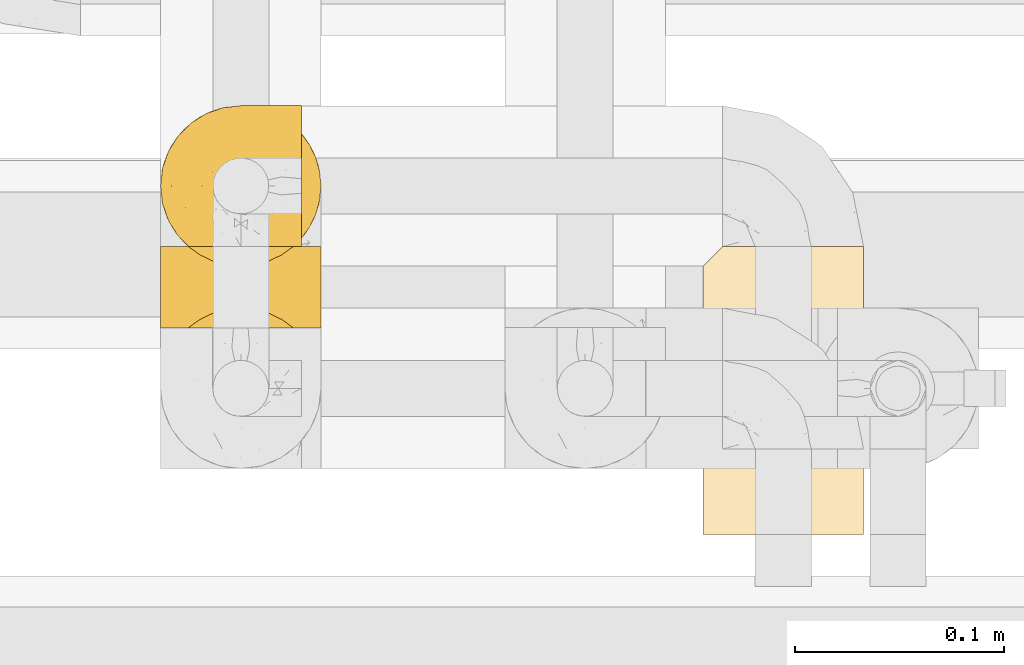
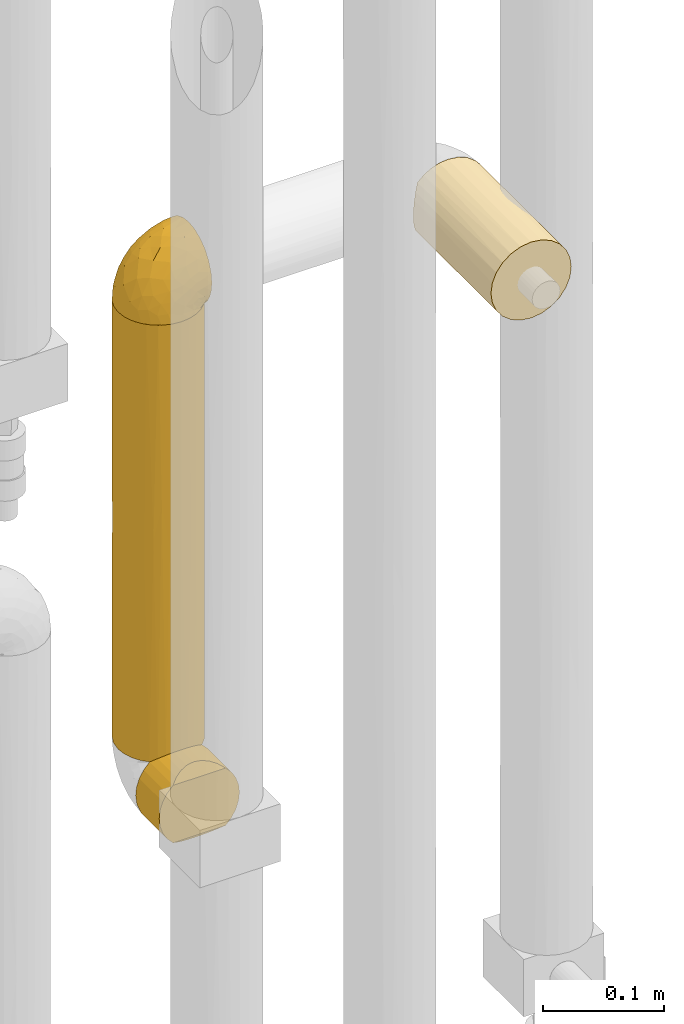
# One storey, part 283 of 827: 4 coverings.
"""IFC2X3 building model written with IfcOpenShell, lengths in millimetres."""

from ifc_helpers import new_model, entity, si_unit, converted_unit, derived_unit, direction, frame, origin, place, context, subcontext, project, spatial, faceted_brep, element, save


model = new_model("IFC2X3")

# Units and contexts
model_context = context("Model", 3, precision=0.01, world=origin(), true_north=direction((6.12303176911189e-17, 1.0)))
body_context = subcontext(model_context, "Body", "Model", "MODEL_VIEW")
ifc_project = project(units=[si_unit("LENGTHUNIT", "METRE", prefix="MILLI"), si_unit("AREAUNIT", "SQUARE_METRE"), si_unit("VOLUMEUNIT", "CUBIC_METRE"), converted_unit("PLANEANGLEUNIT", "DEGREE", entity("IfcRatioMeasure", 0.0174532925199433), si_unit("PLANEANGLEUNIT", "RADIAN"), dimensions=[0, 0, 0, 0, 0, 0, 0]), si_unit("MASSUNIT", "GRAM", prefix="KILO"), derived_unit("MASSDENSITYUNIT", [(si_unit("MASSUNIT", "GRAM", prefix="KILO"), 1), (si_unit("LENGTHUNIT", "METRE"), -3)]), derived_unit("MOMENTOFINERTIAUNIT", [(si_unit("LENGTHUNIT", "METRE"), 4)]), si_unit("TIMEUNIT", "SECOND"), si_unit("FREQUENCYUNIT", "HERTZ"), si_unit("THERMODYNAMICTEMPERATUREUNIT", "DEGREE_CELSIUS"), derived_unit("THERMALTRANSMITTANCEUNIT", [(si_unit("MASSUNIT", "GRAM", prefix="KILO"), 1), (si_unit("THERMODYNAMICTEMPERATUREUNIT", "KELVIN"), -1), (si_unit("TIMEUNIT", "SECOND"), -3)]), derived_unit("VOLUMETRICFLOWRATEUNIT", [(si_unit("LENGTHUNIT", "METRE"), 3), (si_unit("TIMEUNIT", "SECOND"), -1)]), derived_unit("MASSFLOWRATEUNIT", [(si_unit("MASSUNIT", "GRAM", prefix="KILO"), 1), (si_unit("TIMEUNIT", "SECOND"), -1)]), derived_unit("ROTATIONALFREQUENCYUNIT", [(si_unit("TIMEUNIT", "SECOND"), -1)]), si_unit("ELECTRICCURRENTUNIT", "AMPERE"), si_unit("ELECTRICVOLTAGEUNIT", "VOLT"), si_unit("POWERUNIT", "WATT"), si_unit("FORCEUNIT", "NEWTON", prefix="KILO"), si_unit("ILLUMINANCEUNIT", "LUX"), si_unit("LUMINOUSFLUXUNIT", "LUMEN"), si_unit("LUMINOUSINTENSITYUNIT", "CANDELA"), derived_unit("USERDEFINED", [(si_unit("MASSUNIT", "GRAM", prefix="KILO"), -1), (si_unit("LENGTHUNIT", "METRE"), -2), (si_unit("TIMEUNIT", "SECOND"), 3), (si_unit("LUMINOUSFLUXUNIT", "LUMEN"), 1)]), derived_unit("LINEARVELOCITYUNIT", [(si_unit("LENGTHUNIT", "METRE"), 1), (si_unit("TIMEUNIT", "SECOND"), -1)]), si_unit("PRESSUREUNIT", "PASCAL"), derived_unit("USERDEFINED", [(si_unit("LENGTHUNIT", "METRE"), -2), (si_unit("MASSUNIT", "GRAM", prefix="KILO"), 1), (si_unit("TIMEUNIT", "SECOND"), -2)]), derived_unit("LINEARFORCEUNIT", [(si_unit("MASSUNIT", "GRAM", prefix="KILO"), 1), (si_unit("LENGTHUNIT", "METRE"), 1), (si_unit("TIMEUNIT", "SECOND"), -2), (si_unit("LENGTHUNIT", "METRE"), -1)]), derived_unit("PLANARFORCEUNIT", [(si_unit("MASSUNIT", "GRAM", prefix="KILO"), 1), (si_unit("LENGTHUNIT", "METRE"), 1), (si_unit("TIMEUNIT", "SECOND"), -2), (si_unit("LENGTHUNIT", "METRE"), -2)])], contexts=[model_context])

# Site, building, storey
site_placement = place(None, origin())
site = spatial("IfcSite", under=ifc_project, at=site_placement, CompositionType="ELEMENT")
building_placement = place(site_placement, origin())
building = spatial("IfcBuilding", under=site, at=building_placement, CompositionType="ELEMENT")
storey_placement = place(building_placement, frame((0.0, 0.0, 28200.0)))
storey = spatial("IfcBuildingStorey", under=building, at=storey_placement, Name="08", CompositionType="ELEMENT", Elevation=28200.0)

# Coverings
covering_1_placement = place(storey_placement, frame((35047.85, 14854.91, 2170.0)))
element("IfcCovering", 1, at=covering_1_placement, inside=storey, Name=":ADSK_", ObjectType=":ADSK_", PredefinedType="INSULATION", context=body_context, shape_type="Brep", body=[
    faceted_brep([(30.06, 0.0, 2.9), (40.0, 0.0, 1.6), (49.93, 0.0, 2.9), (59.2, 0.0, 6.74), (67.15, 0.0, 12.84), (73.25, 0.0, 20.8), (77.09, 0.0, 30.06), (78.4, 0.0, 40.0), (77.09, 0.0, 49.93), (73.25, 0.0, 59.2), (67.15, 0.0, 67.15), (59.2, 0.0, 73.25), (49.93, 0.0, 77.09), (40.0, 0.0, 78.4), (30.06, 0.0, 77.09), (20.8, 0.0, 73.25), (12.84, 0.0, 67.15), (6.74, 0.0, 59.2), (2.9, 0.0, 49.93), (1.6, 0.0, 40.0), (2.9, 0.0, 30.06), (6.74, 0.0, 20.8), (12.84, 0.0, 12.84), (20.8, 0.0, 6.74), (40.0, 137.9, 1.6), (31.79, 137.9, 2.48), (23.98, 137.9, 5.09), (16.91, 137.9, 9.31), (10.9, 137.9, 14.94), (10.9, 137.9, 65.05), (16.91, 137.9, 70.68), (23.98, 137.9, 74.9), (31.79, 137.9, 77.51), (40.0, 137.9, 78.4), (49.93, 137.9, 77.09), (59.2, 137.9, 73.25), (67.15, 137.9, 67.15), (73.25, 137.9, 59.2), (77.09, 137.9, 49.93), (78.4, 137.9, 40.0), (77.09, 137.9, 30.06), (73.25, 137.9, 20.8), (67.15, 137.9, 12.84), (59.2, 137.9, 6.74), (49.93, 137.9, 2.9), (2.2, 129.2, 33.21), (4.0, 131.0, 26.63), (6.92, 133.92, 20.48), (1.6, 128.6, 40.0), (6.92, 133.92, 59.51), (4.0, 131.0, 53.36), (2.2, 129.2, 46.78)], [[[0, 1, 2, 3, 4, 5, 6, 7, 8, 9, 10, 11, 12, 13, 14, 15, 16, 17, 18, 19, 20, 21, 22, 23]], [[24, 25, 26, 27, 28, 29, 30, 31, 32, 33, 34, 35, 36, 37, 38, 39, 40, 41, 42, 43, 44]], [[45, 46, 20]], [[47, 28, 21]], [[46, 47, 21]], [[48, 45, 19]], [[19, 45, 20]], [[46, 21, 20]], [[28, 22, 21]], [[23, 27, 26]], [[0, 26, 25]], [[1, 25, 24]], [[22, 27, 23]], [[23, 26, 0]], [[25, 1, 0]], [[27, 22, 28]], [[2, 1, 24, 44]], [[3, 2, 44, 43]], [[43, 42, 4, 3]], [[6, 5, 41, 40]], [[7, 6, 40, 39]], [[42, 41, 5, 4]], [[8, 7, 39, 38]], [[9, 8, 38, 37]], [[37, 36, 10, 9]], [[12, 11, 35, 34]], [[13, 12, 34, 33]], [[36, 35, 11, 10]], [[13, 33, 32]], [[14, 32, 31]], [[15, 31, 30]], [[13, 32, 14]], [[14, 31, 15]], [[30, 16, 15]], [[30, 29, 16]], [[29, 49, 17]], [[50, 51, 18]], [[49, 50, 17]], [[17, 50, 18]], [[19, 18, 51]], [[48, 19, 51]], [[29, 17, 16]], [[48, 51, 50, 49, 29, 28, 47, 46, 45]]]),
])
covering_2_placement = place(storey_placement, frame((34787.85, 14981.91, 1737.5)))
element("IfcCovering", 2, at=covering_2_placement, inside=storey, Name=":ADSK_", ObjectType=":ADSK_", PredefinedType="INSULATION", context=body_context, shape_type="Brep", body=[
    faceted_brep([(56.01, 5.09, 443.4), (63.08, 9.31, 443.4), (69.1, 14.94, 443.4), (69.1, 65.05, 443.4), (63.08, 70.68, 443.4), (56.01, 74.9, 443.4), (48.2, 77.51, 443.4), (40.0, 78.4, 443.4), (30.06, 77.09, 443.4), (20.8, 73.25, 443.4), (12.84, 67.15, 443.4), (6.74, 59.2, 443.4), (2.9, 49.93, 443.4), (1.6, 40.0, 443.4), (2.9, 30.06, 443.4), (6.74, 20.8, 443.4), (12.84, 12.84, 443.4), (20.8, 6.74, 443.4), (30.06, 2.9, 443.4), (40.0, 1.6, 443.4), (48.2, 2.48, 443.4), (73.25, 59.2, 1.6), (77.09, 49.93, 1.6), (78.4, 40.0, 1.6), (77.51, 31.79, 1.6), (74.9, 23.98, 1.6), (70.68, 16.91, 1.6), (65.05, 10.9, 1.6), (14.94, 10.9, 1.6), (9.31, 16.91, 1.6), (5.09, 23.98, 1.6), (2.48, 31.79, 1.6), (1.6, 40.0, 1.6), (2.9, 49.93, 1.6), (6.74, 59.2, 1.6), (12.84, 67.15, 1.6), (20.8, 73.25, 1.6), (30.06, 77.09, 1.6), (40.0, 78.4, 1.6), (49.93, 77.09, 1.6), (59.2, 73.25, 1.6), (67.15, 67.15, 1.6), (77.02, 29.82, 225.77), (77.79, 33.21, 434.7), (76.0, 26.63, 436.5), (62.49, 8.87, 212.99), (59.51, 6.92, 5.57), (50.17, 2.97, 219.22), (53.36, 4.0, 8.5), (56.58, 5.36, 182.06), (40.0, 1.6, 227.27), (46.78, 2.2, 10.29), (40.0, 1.6, 10.9), (78.4, 40.0, 217.72), (71.12, 17.5, 232.0), (74.63, 23.41, 262.93), (78.4, 40.0, 434.1), (73.07, 20.48, 439.42), (77.02, 50.17, 229.68), (74.64, 56.56, 184.42), (71.11, 62.5, 217.9), (65.94, 68.31, 244.29), (77.79, 46.78, 434.7), (76.0, 53.36, 436.5), (73.07, 59.51, 439.42), (59.66, 72.98, 238.22), (52.17, 76.41, 233.35), (40.0, 78.4, 227.02), (32.5, 77.66, 238.05), (25.3, 75.47, 222.5), (2.33, 47.48, 237.84), (4.52, 54.69, 222.5), (16.62, 70.46, 222.5), (9.53, 63.37, 222.5), (1.6, 40.0, 217.97), (3.58, 27.82, 211.64), (7.01, 20.33, 206.77), (20.48, 6.92, 5.57), (23.43, 5.35, 260.57), (17.49, 8.88, 227.09), (29.82, 2.97, 215.31), (33.21, 2.2, 10.29), (11.69, 14.05, 200.7), (26.63, 4.0, 8.5)], [[[0, 1, 2, 3, 4, 5, 6, 7, 8, 9, 10, 11, 12, 13, 14, 15, 16, 17, 18, 19, 20]], [[21, 22, 23, 24, 25, 26, 27, 28, 29, 30, 31, 32, 33, 34, 35, 36, 37, 38, 39, 40, 41]], [[42, 43, 44]], [[0, 45, 1]], [[46, 27, 45]], [[47, 48, 49]], [[19, 50, 20]], [[45, 49, 46]], [[50, 47, 20]], [[50, 51, 47]], [[52, 51, 50]], [[0, 20, 47]], [[53, 42, 24]], [[45, 54, 2]], [[49, 0, 47]], [[42, 44, 55]], [[2, 1, 45]], [[55, 25, 42]], [[25, 24, 42]], [[25, 55, 54]], [[53, 56, 43]], [[25, 54, 26]], [[57, 2, 54]], [[47, 51, 48]], [[27, 26, 54]], [[53, 43, 42]], [[23, 53, 24]], [[55, 57, 54]], [[0, 49, 45]], [[57, 55, 44]], [[27, 54, 45]], [[46, 49, 48]], [[53, 22, 58]], [[22, 53, 23]], [[22, 59, 58]], [[21, 60, 59]], [[40, 61, 41]], [[62, 58, 63]], [[62, 56, 53]], [[59, 63, 58]], [[59, 64, 63]], [[21, 41, 60]], [[60, 3, 64]], [[53, 58, 62]], [[40, 65, 61]], [[41, 61, 60]], [[40, 39, 66]], [[66, 65, 40]], [[3, 61, 4]], [[67, 7, 6]], [[66, 6, 5]], [[4, 65, 5]], [[67, 66, 39]], [[66, 5, 65]], [[67, 6, 66]], [[38, 67, 39]], [[65, 4, 61]], [[3, 60, 61]], [[64, 59, 60]], [[59, 22, 21]], [[68, 37, 69]], [[33, 70, 71]], [[68, 7, 67, 38]], [[69, 37, 36]], [[68, 38, 37]], [[8, 69, 9]], [[69, 8, 68]], [[72, 10, 9]], [[72, 69, 36]], [[73, 72, 35]], [[13, 70, 32, 74]], [[71, 34, 33]], [[70, 12, 71]], [[13, 12, 70]], [[73, 11, 10]], [[71, 73, 34]], [[32, 70, 33]], [[71, 11, 73]], [[72, 73, 10]], [[35, 72, 36]], [[11, 71, 12]], [[34, 73, 35]], [[7, 68, 8]], [[69, 72, 9]], [[74, 31, 75]], [[75, 30, 76]], [[77, 78, 79]], [[18, 78, 80]], [[76, 30, 29]], [[50, 80, 81]], [[31, 74, 32]], [[75, 31, 30]], [[75, 15, 14]], [[15, 76, 82]], [[78, 18, 17]], [[79, 82, 28]], [[78, 83, 80]], [[15, 82, 16]], [[81, 80, 83]], [[17, 16, 79]], [[81, 52, 50]], [[83, 78, 77]], [[74, 75, 14]], [[78, 17, 79]], [[75, 76, 15]], [[50, 19, 18]], [[18, 80, 50]], [[76, 29, 82]], [[28, 82, 29]], [[77, 79, 28]], [[16, 82, 79]], [[13, 74, 14]], [[2, 57, 44, 43, 56, 62, 63, 64, 3]], [[48, 51, 52, 81, 83, 77, 28, 27, 46]]]),
])
covering_3_placement = place(storey_placement, frame((34787.85, 14952.32, 1670.0)))
element("IfcCovering", 3, at=covering_3_placement, inside=storey, Name=":ADSK_", ObjectType=":ADSK_", PredefinedType="INSULATION", context=body_context, shape_type="Brep", body=[
    faceted_brep([(1.6, 1.6, 40.0), (2.47, 1.6, 31.83), (5.06, 1.6, 24.05), (9.24, 1.6, 17.0), (14.82, 1.6, 11.0), (65.17, 1.6, 11.0), (70.75, 1.6, 17.0), (74.93, 1.6, 24.05), (77.52, 1.6, 31.83), (78.4, 1.6, 40.0), (77.52, 1.6, 48.16), (74.93, 1.6, 55.94), (70.75, 1.6, 62.99), (65.17, 1.6, 69.0), (14.82, 1.6, 69.0), (9.24, 1.6, 62.99), (5.06, 1.6, 55.94), (2.47, 1.6, 48.16), (40.0, 40.49, 1.6), (30.06, 40.49, 2.9), (20.8, 40.49, 6.74), (12.84, 40.49, 12.84), (6.74, 40.49, 20.8), (2.9, 40.49, 30.06), (1.6, 40.49, 40.0), (2.48, 40.49, 48.2), (5.09, 40.49, 56.01), (9.31, 40.49, 63.08), (14.94, 40.49, 69.1), (65.05, 40.49, 69.1), (70.68, 40.49, 63.08), (74.9, 40.49, 56.01), (77.51, 40.49, 48.2), (78.4, 40.49, 40.0), (77.09, 40.49, 30.06), (73.25, 40.49, 20.8), (67.15, 40.49, 12.84), (59.2, 40.49, 6.74), (49.93, 40.49, 2.9), (46.82, 10.38, 2.21), (40.0, 11.0, 1.6), (53.43, 8.57, 4.02), (59.61, 5.61, 6.98), (59.51, 36.52, 73.07), (59.61, 5.61, 73.01), (53.36, 33.59, 76.0), (46.78, 31.8, 77.79), (46.82, 10.38, 77.78), (53.43, 8.57, 75.97), (40.0, 11.0, 78.4), (40.0, 31.19, 78.4), (33.21, 31.8, 77.79), (26.63, 33.59, 76.0), (33.17, 10.38, 77.78), (20.48, 36.52, 73.07), (20.38, 5.61, 73.01), (26.56, 8.57, 75.97), (26.56, 8.57, 4.02), (33.17, 10.38, 2.21), (20.38, 5.61, 6.98)], [[[0, 1, 2, 3, 4, 5, 6, 7, 8, 9, 10, 11, 12, 13, 14, 15, 16, 17]], [[18, 19, 20, 21, 22, 23, 24, 25, 26, 27, 28, 29, 30, 31, 32, 33, 34, 35, 36, 37, 38]], [[39, 40, 18]], [[39, 18, 38]], [[41, 38, 37]], [[41, 39, 38]], [[36, 5, 42]], [[41, 37, 42]], [[42, 37, 36]], [[6, 36, 35]], [[35, 34, 7]], [[33, 8, 34]], [[6, 35, 7]], [[7, 34, 8]], [[33, 9, 8]], [[36, 6, 5]], [[10, 33, 32]], [[11, 32, 31]], [[12, 31, 30]], [[9, 33, 10]], [[11, 10, 32]], [[13, 12, 30]], [[12, 11, 31]], [[30, 29, 13]], [[29, 43, 44]], [[45, 46, 47]], [[43, 45, 48]], [[44, 43, 48]], [[46, 49, 47]], [[47, 48, 45]], [[49, 46, 50]], [[29, 44, 13]], [[51, 52, 53]], [[54, 28, 55]], [[52, 54, 56]], [[50, 51, 49]], [[49, 51, 53]], [[53, 52, 56]], [[54, 55, 56]], [[28, 14, 55]], [[15, 27, 26]], [[16, 26, 25]], [[17, 25, 24]], [[14, 27, 15]], [[16, 15, 26]], [[25, 17, 16]], [[24, 0, 17]], [[27, 14, 28]], [[1, 24, 23]], [[22, 21, 3]], [[2, 23, 22]], [[0, 24, 1]], [[2, 1, 23]], [[3, 2, 22]], [[21, 4, 3]], [[57, 20, 19]], [[19, 18, 58]], [[40, 58, 18]], [[4, 21, 59]], [[58, 57, 19]], [[59, 20, 57]], [[59, 21, 20]], [[59, 57, 58, 40, 39, 41, 42, 5, 4]], [[44, 48, 47, 49, 53, 56, 55, 14, 13]], [[54, 52, 51, 50, 46, 45, 43, 29, 28]]]),
])
covering_4_placement = place(storey_placement, frame((34787.8, 14981.86, 2179.3)))
element("IfcCovering", 4, at=covering_4_placement, inside=storey, Name=":ADSK_", ObjectType=":ADSK_", PredefinedType="INSULATION", context=body_context, shape_type="Brep", body=[
    faceted_brep([(23.36, 5.41, 1.6), (16.07, 9.99, 1.6), (9.98, 16.08, 1.6), (5.4, 23.37, 1.6), (2.56, 31.49, 1.6), (1.6, 40.05, 1.6), (2.56, 48.61, 1.6), (5.41, 56.73, 1.6), (9.99, 64.02, 1.6), (16.08, 70.11, 1.6), (23.37, 74.69, 1.6), (31.49, 77.53, 1.6), (40.05, 78.5, 1.6), (48.15, 77.63, 1.6), (55.88, 75.08, 1.6), (62.9, 70.97, 1.6), (68.89, 65.47, 1.6), (68.89, 63.27, 1.6), (68.89, 61.53, 1.6), (68.89, 59.57, 1.6), (68.89, 57.6, 1.6), (68.89, 55.63, 1.6), (68.89, 53.67, 1.6), (68.89, 51.7, 1.6), (68.89, 49.73, 1.6), (68.89, 47.54, 1.6), (68.89, 45.34, 1.6), (68.89, 43.15, 1.6), (68.89, 40.96, 1.6), (68.89, 38.76, 1.6), (68.89, 36.57, 1.6), (68.89, 34.37, 1.6), (68.89, 32.18, 1.6), (68.89, 29.98, 1.6), (68.89, 27.79, 1.6), (68.89, 25.6, 1.6), (68.89, 23.4, 1.6), (68.89, 21.21, 1.6), (68.89, 19.01, 1.6), (68.89, 16.82, 1.6), (68.89, 14.62, 1.6), (62.89, 9.12, 1.6), (55.86, 5.0, 1.6), (48.13, 2.46, 1.6), (40.05, 1.6, 1.6), (31.49, 2.56, 1.6), (69.15, 65.47, 1.85), (69.15, 70.97, 7.85), (69.15, 75.09, 14.87), (69.15, 77.63, 22.6), (69.15, 78.5, 30.7), (69.15, 77.19, 40.65), (69.15, 73.34, 49.92), (69.15, 67.23, 57.88), (69.15, 59.27, 63.99), (69.15, 50.0, 67.84), (69.15, 40.05, 69.15), (69.15, 30.09, 67.84), (69.15, 20.82, 63.99), (69.15, 12.86, 57.88), (69.15, 6.75, 49.92), (69.15, 2.91, 40.65), (69.15, 1.6, 30.7), (69.15, 2.46, 22.6), (69.15, 5.0, 14.87), (69.15, 9.12, 7.85), (69.15, 14.62, 1.85), (69.15, 16.82, 1.85), (69.15, 17.8, 1.85), (69.15, 19.39, 1.85), (69.15, 20.98, 1.85), (69.15, 22.57, 1.85), (69.15, 24.16, 1.85), (69.15, 25.75, 1.85), (69.15, 27.33, 1.85), (69.15, 28.92, 1.85), (69.15, 30.51, 1.85), (69.15, 32.1, 1.85), (69.15, 33.69, 1.85), (69.15, 35.28, 1.85), (69.15, 36.87, 1.85), (69.15, 38.46, 1.85), (69.15, 40.05, 1.85), (69.15, 41.63, 1.85), (69.15, 43.22, 1.85), (69.15, 44.81, 1.85), (69.15, 46.4, 1.85), (69.15, 47.99, 1.85), (69.15, 49.58, 1.85), (69.15, 51.17, 1.85), (69.15, 52.76, 1.85), (69.15, 54.72, 1.85), (69.15, 56.69, 1.85), (69.15, 58.88, 1.85), (69.15, 61.08, 1.85), (69.15, 63.27, 1.85), (68.96, 37.77, 1.77), (68.97, 36.07, 1.78), (68.97, 32.96, 1.77), (68.97, 31.36, 1.77), (68.95, 56.52, 1.76), (68.96, 54.96, 1.77), (68.98, 18.75, 1.79), (68.97, 58.07, 1.78), (68.97, 50.37, 1.78), (68.98, 23.36, 1.78), (68.97, 24.95, 1.78), (68.97, 42.43, 1.78), (68.94, 15.97, 1.74), (68.98, 51.96, 1.78), (68.98, 53.47, 1.78), (68.96, 48.63, 1.77), (68.97, 63.93, 1.78), (68.98, 40.93, 1.78), (68.98, 29.72, 1.78), (68.97, 62.4, 1.77), (68.96, 60.92, 1.77), (68.97, 17.31, 1.77), (68.97, 21.74, 1.78), (68.98, 34.56, 1.78), (68.96, 20.18, 1.77), (68.97, 14.62, 1.77), (68.94, 14.62, 1.72), (68.92, 14.62, 1.66), (68.97, 65.47, 1.77), (69.02, 65.47, 1.8), (69.08, 65.47, 1.82), (68.98, 59.5, 1.79), (68.97, 47.1, 1.78), (68.98, 45.61, 1.79), (68.97, 28.18, 1.78), (69.08, 14.62, 1.82), (69.02, 14.62, 1.8), (68.96, 26.61, 1.76), (68.92, 65.47, 1.66), (68.94, 65.47, 1.72), (68.97, 39.32, 1.78), (68.96, 44.12, 1.77), (67.02, 72.26, 9.41), (63.33, 76.57, 17.65), (64.61, 71.77, 7.41), (49.27, 78.5, 21.47), (51.4, 77.9, 15.21), (43.94, 78.5, 16.15), (61.87, 78.5, 28.75), (61.54, 75.52, 13.67), (57.95, 76.13, 12.79), (56.12, 77.81, 19.18), (65.41, 72.4, 9.04), (53.1, 76.56, 7.41), (63.04, 71.77, 5.74), (61.33, 72.25, 3.72), (41.99, 78.5, 8.87), (54.6, 78.5, 26.8), (56.6, 75.75, 9.53), (41.58, 78.5, 7.34), (61.54, 75.57, 44.74), (28.67, 76.34, 12.03), (58.75, 77.64, 37.26), (46.12, 63.45, 56.57), (55.56, 70.55, 52.31), (42.09, 71.02, 45.87), (17.15, 66.15, 25.73), (12.68, 60.51, 26.34), (20.17, 63.72, 35.21), (52.38, 75.57, 42.07), (23.76, 72.61, 21.49), (34.7, 76.83, 22.52), (20.5, 72.61, 11.02), (14.64, 67.24, 15.64), (49.4, 47.19, 65.49), (52.34, 54.76, 63.99), (58.67, 63.45, 60.27), (5.82, 52.75, 17.92), (30.64, 53.89, 53.93), (26.66, 46.73, 53.36), (37.53, 48.67, 60.18), (41.11, 55.34, 59.54), (21.38, 40.05, 49.36), (13.72, 50.46, 37.63), (6.74, 40.05, 27.45), (14.06, 40.05, 38.4), (41.77, 77.74, 26.02), (51.58, 77.66, 34.22), (16.28, 57.43, 36.59), (4.3, 40.05, 15.2), (8.62, 60.51, 13.32), (25.26, 60.1, 45.25), (21.47, 51.88, 46.78), (33.37, 72.59, 35.9), (41.35, 76.05, 33.87), (55.54, 40.05, 66.44), (35.17, 63.95, 50.09), (29.04, 67.24, 41.08), (24.34, 69.62, 31.14), (29.33, 73.6, 28.19), (43.3, 40.05, 64.0), (32.34, 40.05, 56.68), (49.41, 32.72, 65.46), (41.58, 1.6, 7.34), (28.66, 3.75, 12.03), (13.7, 29.63, 37.61), (27.85, 27.18, 52.22), (5.82, 27.35, 17.91), (12.67, 19.59, 26.34), (19.45, 12.86, 28.05), (14.63, 12.86, 15.64), (23.75, 7.49, 21.48), (48.85, 9.54, 50.02), (54.13, 16.64, 59.28), (37.84, 17.48, 53.05), (55.15, 2.33, 35.39), (54.6, 1.6, 26.8), (61.87, 1.6, 28.75), (37.91, 8.17, 41.4), (50.18, 4.3, 40.48), (57.58, 26.94, 65.81), (20.83, 20.75, 41.02), (59.91, 9.54, 53.28), (57.75, 4.52, 43.9), (20.49, 7.49, 11.01), (41.99, 1.6, 8.87), (43.94, 1.6, 16.15), (8.61, 19.59, 13.31), (34.7, 3.27, 22.54), (42.64, 2.45, 27.68), (49.27, 1.6, 21.47), (36.94, 31.21, 59.8), (45.72, 25.33, 61.82), (62.29, 2.29, 37.3), (29.01, 12.86, 41.07), (31.47, 6.89, 32.24), (49.29, 2.23, 31.68), (37.18, 12.43, 47.4), (43.45, 4.1, 35.77), (63.33, 3.53, 17.65), (67.23, 6.88, 11.06), (66.07, 8.16, 8.55), (65.22, 9.02, 6.63), (61.99, 5.0, 12.77), (57.95, 3.96, 12.79), (53.09, 3.52, 7.41), (56.84, 2.4, 18.97), (61.33, 7.83, 3.72), (63.06, 8.32, 5.76), (51.41, 2.19, 15.21), (56.61, 4.34, 9.52)], [[[0, 1, 2, 3, 4, 5, 6, 7, 8, 9, 10, 11, 12, 13, 14, 15, 16, 17, 18, 19, 20, 21, 22, 23, 24, 25, 26, 27, 28, 29, 30, 31, 32, 33, 34, 35, 36, 37, 38, 39, 40, 41, 42, 43, 44, 45]], [[46, 47, 48, 49, 50, 51, 52, 53, 54, 55, 56, 57, 58, 59, 60, 61, 62, 63, 64, 65, 66, 67, 68, 69, 70, 71, 72, 73, 74, 75, 76, 77, 78, 79, 80, 81, 82, 83, 84, 85, 86, 87, 88, 89, 90, 91, 92, 93, 94, 95]], [[96, 97, 30]], [[98, 77, 99]], [[100, 101, 21]], [[69, 68, 102]], [[20, 19, 103]], [[24, 23, 104]], [[20, 103, 100]], [[72, 105, 106]], [[84, 83, 107]], [[89, 88, 104]], [[108, 67, 66]], [[109, 110, 90]], [[111, 25, 24]], [[112, 17, 16]], [[82, 113, 83]], [[109, 23, 22]], [[114, 76, 75]], [[105, 36, 106]], [[104, 111, 24]], [[18, 115, 116]], [[97, 96, 80]], [[67, 108, 117]], [[105, 71, 118]], [[31, 97, 119]], [[102, 120, 69]], [[108, 121, 122, 123, 40]], [[112, 95, 115]], [[17, 115, 18]], [[94, 116, 115]], [[117, 68, 67]], [[38, 117, 39]], [[112, 124, 125, 126, 46]], [[17, 112, 115]], [[70, 120, 118]], [[39, 117, 108]], [[120, 38, 37]], [[120, 37, 118]], [[120, 70, 69]], [[116, 94, 127]], [[128, 86, 129]], [[117, 38, 102]], [[74, 130, 75]], [[99, 33, 32]], [[115, 95, 94]], [[39, 108, 40]], [[108, 66, 131, 132, 121]], [[105, 72, 71]], [[118, 37, 36]], [[71, 70, 118]], [[35, 106, 36]], [[36, 105, 118]], [[35, 133, 106]], [[74, 73, 133]], [[106, 133, 73]], [[99, 114, 33]], [[133, 35, 34]], [[73, 72, 106]], [[95, 112, 46]], [[112, 16, 134, 135, 124]], [[130, 114, 75]], [[99, 76, 114]], [[114, 130, 33]], [[34, 33, 130]], [[78, 77, 98]], [[98, 119, 78]], [[130, 133, 34]], [[133, 130, 74]], [[79, 97, 80]], [[98, 99, 32]], [[98, 32, 31]], [[77, 76, 99]], [[97, 79, 119]], [[136, 96, 29]], [[30, 97, 31]], [[136, 29, 28]], [[81, 80, 96]], [[29, 96, 30]], [[31, 119, 98]], [[119, 79, 78]], [[96, 136, 81]], [[82, 81, 136]], [[113, 107, 83]], [[84, 107, 137]], [[107, 27, 137]], [[113, 28, 107]], [[27, 107, 28]], [[85, 84, 137]], [[137, 27, 26]], [[113, 136, 28]], [[136, 113, 82]], [[109, 89, 104]], [[86, 85, 129]], [[89, 109, 90]], [[111, 87, 128]], [[26, 129, 137]], [[88, 111, 104]], [[25, 111, 128]], [[22, 110, 109]], [[23, 109, 104]], [[110, 91, 90]], [[100, 92, 101]], [[110, 22, 101]], [[91, 110, 101]], [[116, 19, 18]], [[111, 88, 87]], [[127, 103, 19]], [[25, 128, 26]], [[86, 128, 87]], [[128, 129, 26]], [[137, 129, 85]], [[120, 102, 38]], [[117, 102, 68]], [[91, 101, 92]], [[21, 101, 22]], [[93, 92, 103]], [[100, 21, 20]], [[100, 103, 92]], [[127, 93, 103]], [[93, 127, 94]], [[116, 127, 19]], [[126, 138, 47]], [[48, 138, 139]], [[140, 125, 124]], [[141, 142, 143]], [[144, 49, 139]], [[145, 140, 146]], [[48, 139, 49]], [[139, 145, 147]], [[144, 50, 49]], [[126, 125, 148]], [[14, 13, 149]], [[150, 146, 140]], [[148, 140, 145]], [[151, 150, 135]], [[151, 14, 149]], [[16, 15, 134]], [[13, 152, 149]], [[124, 150, 140]], [[141, 147, 142]], [[14, 151, 15]], [[15, 151, 134]], [[47, 46, 126]], [[139, 153, 144]], [[138, 48, 47]], [[125, 140, 148]], [[135, 134, 151]], [[146, 154, 142]], [[145, 146, 147]], [[148, 139, 138]], [[147, 141, 153]], [[147, 146, 142]], [[139, 147, 153]], [[139, 148, 145]], [[148, 138, 126]], [[154, 146, 150]], [[149, 143, 142]], [[151, 154, 150]], [[149, 142, 154]], [[13, 12, 155, 152]], [[152, 143, 149]], [[151, 149, 154]], [[150, 124, 135]], [[51, 156, 52]], [[155, 11, 157]], [[50, 144, 158]], [[159, 160, 161]], [[162, 163, 164]], [[158, 165, 156]], [[157, 166, 167]], [[166, 168, 169]], [[170, 55, 171]], [[161, 160, 165]], [[172, 54, 53]], [[160, 53, 52]], [[173, 7, 6]], [[54, 172, 171]], [[174, 175, 176]], [[170, 177, 176]], [[167, 143, 157]], [[178, 179, 180, 181]], [[157, 11, 10]], [[141, 182, 183]], [[160, 52, 156]], [[173, 179, 184]], [[8, 169, 9]], [[173, 6, 185]], [[155, 12, 11]], [[8, 7, 186]], [[162, 169, 163]], [[187, 184, 188]], [[180, 173, 185]], [[10, 168, 157]], [[54, 171, 55]], [[186, 173, 163]], [[157, 143, 152, 155]], [[189, 161, 190]], [[179, 173, 180]], [[9, 168, 10]], [[186, 169, 8]], [[187, 164, 184]], [[144, 183, 158]], [[172, 160, 159]], [[177, 174, 176]], [[55, 170, 191]], [[187, 192, 193]], [[183, 182, 190]], [[166, 194, 195]], [[167, 190, 182]], [[6, 5, 185]], [[173, 186, 7]], [[169, 186, 163]], [[169, 168, 9]], [[157, 168, 166]], [[190, 161, 165]], [[161, 193, 192]], [[183, 165, 158]], [[194, 189, 195]], [[191, 170, 196]], [[191, 56, 55]], [[175, 178, 197]], [[197, 196, 176]], [[170, 176, 196]], [[188, 175, 174]], [[197, 176, 175]], [[177, 170, 171]], [[171, 159, 177]], [[192, 177, 159]], [[187, 188, 174]], [[188, 179, 178]], [[174, 177, 192]], [[164, 187, 193]], [[174, 192, 187]], [[161, 192, 159]], [[194, 164, 193]], [[184, 164, 163]], [[189, 194, 193]], [[162, 166, 169]], [[161, 189, 193]], [[195, 190, 167]], [[173, 184, 163]], [[184, 179, 188]], [[164, 194, 162]], [[166, 162, 194]], [[190, 195, 189]], [[167, 182, 143]], [[167, 166, 195]], [[160, 172, 53]], [[171, 172, 159]], [[51, 50, 158]], [[160, 156, 165]], [[51, 158, 156]], [[183, 144, 153]], [[141, 183, 153]], [[190, 165, 183]], [[178, 175, 188]], [[143, 182, 141]], [[198, 191, 196]], [[45, 199, 200]], [[178, 201, 202]], [[201, 203, 204]], [[205, 206, 207]], [[57, 56, 191]], [[4, 185, 5]], [[208, 209, 210]], [[211, 212, 213]], [[208, 214, 215]], [[216, 209, 58]], [[201, 217, 202]], [[59, 218, 60]], [[60, 218, 219]], [[201, 178, 181, 180]], [[1, 0, 220]], [[201, 180, 203]], [[200, 199, 221, 222]], [[203, 185, 4]], [[3, 203, 4]], [[2, 1, 206]], [[217, 210, 202]], [[58, 209, 59]], [[3, 223, 203]], [[207, 220, 200]], [[204, 223, 206]], [[205, 204, 206]], [[207, 200, 224]], [[200, 222, 224]], [[206, 223, 2]], [[225, 222, 226]], [[220, 206, 1]], [[60, 219, 61]], [[57, 198, 216]], [[227, 202, 228]], [[3, 2, 223]], [[45, 44, 199]], [[0, 45, 200]], [[219, 211, 229]], [[230, 231, 214]], [[231, 207, 224]], [[210, 209, 228]], [[218, 209, 208]], [[226, 232, 225]], [[231, 230, 205]], [[202, 210, 228]], [[233, 230, 214]], [[227, 228, 198]], [[201, 204, 217]], [[211, 232, 212]], [[180, 185, 203]], [[61, 229, 62]], [[203, 223, 204]], [[200, 220, 0]], [[206, 220, 207]], [[225, 231, 224]], [[232, 226, 212]], [[214, 231, 234]], [[197, 227, 196]], [[191, 198, 57]], [[198, 228, 216]], [[202, 197, 178]], [[196, 227, 198]], [[197, 202, 227]], [[209, 216, 228]], [[58, 57, 216]], [[229, 211, 213]], [[215, 211, 219]], [[205, 217, 204]], [[210, 217, 230]], [[62, 229, 213]], [[219, 229, 61]], [[231, 205, 207]], [[217, 205, 230]], [[215, 214, 234]], [[233, 208, 210]], [[209, 218, 59]], [[219, 218, 208]], [[208, 215, 219]], [[232, 215, 234]], [[215, 232, 211]], [[232, 234, 225]], [[231, 225, 234]], [[222, 225, 224]], [[208, 233, 214]], [[210, 230, 233]], [[63, 213, 235]], [[213, 212, 235]], [[213, 63, 62]], [[236, 235, 237]], [[237, 132, 131]], [[235, 236, 64]], [[238, 239, 240]], [[63, 235, 64]], [[131, 66, 65]], [[236, 131, 65]], [[241, 221, 43]], [[236, 65, 64]], [[238, 121, 132]], [[42, 241, 43]], [[240, 239, 242]], [[41, 123, 243]], [[43, 221, 199, 44]], [[243, 122, 244]], [[226, 245, 242]], [[240, 242, 245]], [[121, 238, 244]], [[41, 40, 123]], [[132, 237, 238]], [[243, 42, 41]], [[131, 236, 237]], [[239, 238, 237]], [[244, 238, 240]], [[246, 240, 245]], [[246, 243, 244]], [[237, 235, 239]], [[242, 235, 212]], [[235, 242, 239]], [[222, 245, 226]], [[242, 212, 226]], [[222, 241, 245]], [[240, 246, 244]], [[245, 241, 246]], [[243, 246, 241]], [[241, 222, 221]], [[42, 243, 241]], [[122, 243, 123]], [[122, 121, 244]]]),
])

save(model, "model.ifc")
